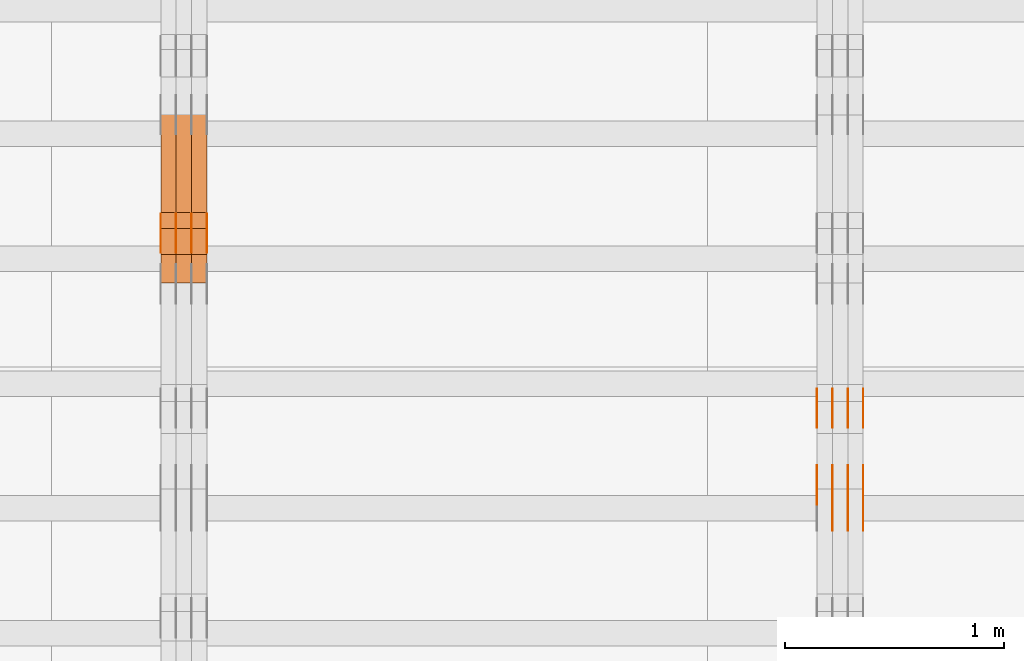
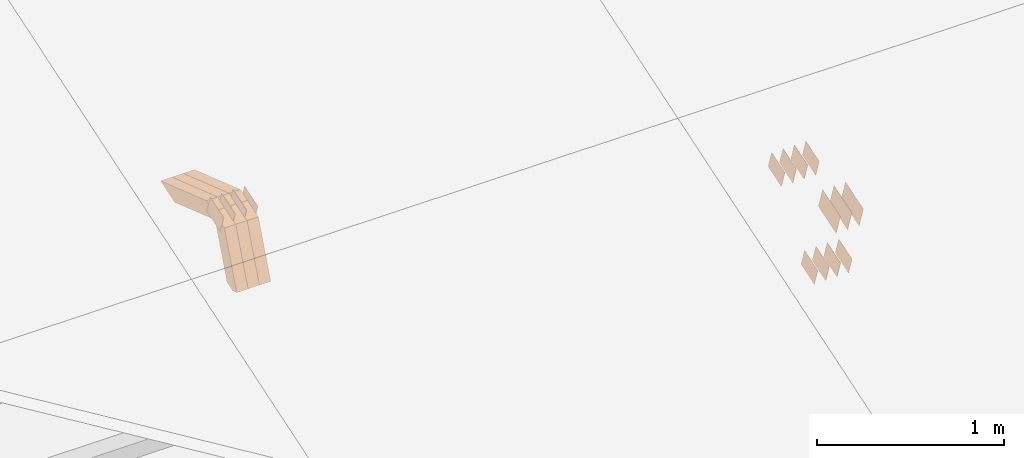
# One storey, part 126 of 385: 28 proxies.
"""IFC2X3 building model written with IfcOpenShell, lengths in millimetres."""

from ifc_helpers import new_model, entity, si_unit, converted_unit, derived_unit, direction, frame, origin, place, context, subcontext, project, spatial, polyline, outline, extrude, source, transform, mapped, material, type_object, type_shapes, element, save


model = new_model("IFC2X3")

# Units and contexts
model_context = context("Model", 3, precision=0.01, world=origin(), true_north=direction((6.12303176911189e-17, 1.0)))
body_context = subcontext(model_context, "Body", "Model", "MODEL_VIEW")
ifc_project = project(units=[si_unit("LENGTHUNIT", "METRE", prefix="MILLI"), si_unit("AREAUNIT", "SQUARE_METRE"), si_unit("VOLUMEUNIT", "CUBIC_METRE"), converted_unit("PLANEANGLEUNIT", "DEGREE", entity("IfcRatioMeasure", 0.0174532925199433), si_unit("PLANEANGLEUNIT", "RADIAN"), dimensions=[0, 0, 0, 0, 0, 0, 0]), si_unit("MASSUNIT", "GRAM", prefix="KILO"), derived_unit("MASSDENSITYUNIT", [(si_unit("MASSUNIT", "GRAM", prefix="KILO"), 1), (si_unit("LENGTHUNIT", "METRE"), -3)]), si_unit("TIMEUNIT", "SECOND"), si_unit("FREQUENCYUNIT", "HERTZ"), si_unit("THERMODYNAMICTEMPERATUREUNIT", "DEGREE_CELSIUS"), derived_unit("THERMALTRANSMITTANCEUNIT", [(si_unit("MASSUNIT", "GRAM", prefix="KILO"), 1), (si_unit("THERMODYNAMICTEMPERATUREUNIT", "KELVIN"), -1), (si_unit("TIMEUNIT", "SECOND"), -3)]), derived_unit("VOLUMETRICFLOWRATEUNIT", [(si_unit("LENGTHUNIT", "METRE"), 3), (si_unit("TIMEUNIT", "SECOND"), -1)]), si_unit("ELECTRICCURRENTUNIT", "AMPERE"), si_unit("ELECTRICVOLTAGEUNIT", "VOLT"), si_unit("POWERUNIT", "WATT"), si_unit("FORCEUNIT", "NEWTON", prefix="KILO"), si_unit("ILLUMINANCEUNIT", "LUX"), si_unit("LUMINOUSFLUXUNIT", "LUMEN"), si_unit("LUMINOUSINTENSITYUNIT", "CANDELA"), derived_unit("USERDEFINED", [(si_unit("MASSUNIT", "GRAM", prefix="KILO"), -1), (si_unit("LENGTHUNIT", "METRE"), -2), (si_unit("TIMEUNIT", "SECOND"), 3), (si_unit("LUMINOUSFLUXUNIT", "LUMEN"), 1)]), derived_unit("LINEARVELOCITYUNIT", [(si_unit("LENGTHUNIT", "METRE"), 1), (si_unit("TIMEUNIT", "SECOND"), -1)]), si_unit("PRESSUREUNIT", "PASCAL"), derived_unit("USERDEFINED", [(si_unit("LENGTHUNIT", "METRE"), -2), (si_unit("MASSUNIT", "GRAM", prefix="KILO"), 1), (si_unit("TIMEUNIT", "SECOND"), -2)])], contexts=[model_context])

# Site, building, storey
site_placement = place(None, origin())
site = spatial("IfcSite", under=ifc_project, at=site_placement, CompositionType="ELEMENT")
building_placement = place(site_placement, origin())
building = spatial("IfcBuilding", under=site, at=building_placement, CompositionType="ELEMENT")
storey_placement = place(building_placement, origin())
storey = spatial("IfcBuildingStorey", under=building, at=storey_placement, Name="Default", CompositionType="ELEMENT", Elevation=0.0)

# Proxies
ifc_material_1 = material(Name="IfcSurfaceStyle #339344")
building_element_proxy_type_1 = type_object("IfcBuildingElementProxyType", PredefinedType="NOTDEFINED", material=ifc_material_1)
shared_shape_1 = source(origin(), body_context, "Body", "SweptSolid", [
    extrude(outline(polyline([(-74.9998707133927, -60.0000596852269), (74.9998841352353, -60.0000596852269), (74.999861282944, 60.0000596852269), (-74.9998747047866, 60.0000596852269), (-74.9998707133927, -60.0000596852269)])), frame((74.9998841352353, 60.0000596852269, 0.0), z_axis=(0.0, 0.0, 1.0), x_axis=(-1.0, 0.0, 0.0)), (0.0, 0.0, 1.0), 1.3),
])
type_shapes(building_element_proxy_type_1, [shared_shape_1])
proxy_1_placement = place(building_placement, frame((27386.3, 5067.4882362875, 826.131473120182), z_axis=(-1.0, 0.0, 0.0), x_axis=(0.0, 0.951056516295124, 0.309016994375039)))
element("IfcBuildingElementProxy", 1, at=proxy_1_placement, inside=storey, type_object=building_element_proxy_type_1, material=ifc_material_1, context=body_context, shape_type="MappedRepresentation", body=[
    mapped(shared_shape_1, transform((0.0, 0.0, 0.0), scale=1.0)),
])
ifc_material_2 = material(Name="IfcSurfaceStyle #339287")
building_element_proxy_type_2 = type_object("IfcBuildingElementProxyType", PredefinedType="NOTDEFINED", material=ifc_material_2)
shared_shape_2 = source(origin(), body_context, "Body", "SweptSolid", [
    extrude(outline(polyline([(-74.9998707133927, -60.0000596852269), (74.9998841352353, -60.0000596852269), (74.999861282944, 60.0000596852269), (-74.9998747047866, 60.0000596852269), (-74.9998707133927, -60.0000596852269)])), frame((74.9998841352353, 60.0000596852269, 0.0), z_axis=(0.0, 0.0, 1.0), x_axis=(-1.0, 0.0, 0.0)), (0.0, 0.0, 1.0), 1.3),
])
type_shapes(building_element_proxy_type_2, [shared_shape_2])
proxy_2_placement = place(building_placement, frame((27315.0, 5067.4882362875, 826.131473120182), z_axis=(-1.0, 0.0, 0.0), x_axis=(0.0, 0.951056516295124, 0.309016994375039)))
element("IfcBuildingElementProxy", 2, at=proxy_2_placement, inside=storey, type_object=building_element_proxy_type_2, material=ifc_material_2, context=body_context, shape_type="MappedRepresentation", body=[
    mapped(shared_shape_2, transform((0.0, 0.0, 0.0), scale=1.0)),
])
ifc_material_3 = material(Name="IfcSurfaceStyle #339230")
building_element_proxy_type_3 = type_object("IfcBuildingElementProxyType", PredefinedType="NOTDEFINED", material=ifc_material_3)
shared_shape_3 = source(origin(), body_context, "Body", "SweptSolid", [
    extrude(outline(polyline([(-74.9998707133927, -60.0000596852269), (74.9998841352353, -60.0000596852269), (74.999861282944, 60.0000596852269), (-74.9998747047866, 60.0000596852269), (-74.9998707133927, -60.0000596852269)])), frame((74.9998841352353, 60.0000596852269, 0.0), z_axis=(0.0, 0.0, 1.0), x_axis=(-1.0, 0.0, 0.0)), (0.0, 0.0, 1.0), 1.3),
])
type_shapes(building_element_proxy_type_3, [shared_shape_3])
proxy_3_placement = place(building_placement, frame((27316.3, 5067.4882362875, 826.131473120182), z_axis=(-1.0, 0.0, 0.0), x_axis=(0.0, 0.951056516295124, 0.309016994375039)))
element("IfcBuildingElementProxy", 3, at=proxy_3_placement, inside=storey, type_object=building_element_proxy_type_3, material=ifc_material_3, context=body_context, shape_type="MappedRepresentation", body=[
    mapped(shared_shape_3, transform((0.0, 0.0, 0.0), scale=1.0)),
])
ifc_material_4 = material(Name="IfcSurfaceStyle #339173")
building_element_proxy_type_4 = type_object("IfcBuildingElementProxyType", PredefinedType="NOTDEFINED", material=ifc_material_4)
shared_shape_4 = source(origin(), body_context, "Body", "SweptSolid", [
    extrude(outline(polyline([(-74.9998707133927, -60.0000596852269), (74.9998841352353, -60.0000596852269), (74.999861282944, 60.0000596852269), (-74.9998747047866, 60.0000596852269), (-74.9998707133927, -60.0000596852269)])), frame((74.9998841352353, 60.0000596852269, 0.0), z_axis=(0.0, 0.0, 1.0), x_axis=(-1.0, 0.0, 0.0)), (0.0, 0.0, 1.0), 1.29999999999999),
])
type_shapes(building_element_proxy_type_4, [shared_shape_4])
proxy_4_placement = place(building_placement, frame((27245.0, 5067.4882362875, 826.131473120182), z_axis=(-1.0, 0.0, 0.0), x_axis=(0.0, 0.951056516295124, 0.309016994375039)))
element("IfcBuildingElementProxy", 4, at=proxy_4_placement, inside=storey, type_object=building_element_proxy_type_4, material=ifc_material_4, context=body_context, shape_type="MappedRepresentation", body=[
    mapped(shared_shape_4, transform((0.0, 0.0, 0.0), scale=1.0)),
])
ifc_material_5 = material(Name="IfcSurfaceStyle #339116")
building_element_proxy_type_5 = type_object("IfcBuildingElementProxyType", PredefinedType="NOTDEFINED", material=ifc_material_5)
shared_shape_5 = source(origin(), body_context, "Body", "SweptSolid", [
    extrude(outline(polyline([(-74.9998707133927, -60.0000596852269), (74.9998841352353, -60.0000596852269), (74.999861282944, 60.0000596852269), (-74.9998747047866, 60.0000596852269), (-74.9998707133927, -60.0000596852269)])), frame((74.9998841352353, 60.0000596852269, 0.0), z_axis=(0.0, 0.0, 1.0), x_axis=(-1.0, 0.0, 0.0)), (0.0, 0.0, 1.0), 1.29999999999999),
])
type_shapes(building_element_proxy_type_5, [shared_shape_5])
proxy_5_placement = place(building_placement, frame((27246.3, 5067.4882362875, 826.131473120182), z_axis=(-1.0, 0.0, 0.0), x_axis=(0.0, 0.951056516295124, 0.309016994375039)))
element("IfcBuildingElementProxy", 5, at=proxy_5_placement, inside=storey, type_object=building_element_proxy_type_5, material=ifc_material_5, context=body_context, shape_type="MappedRepresentation", body=[
    mapped(shared_shape_5, transform((0.0, 0.0, 0.0), scale=1.0)),
])
ifc_material_6 = material(Name="IfcSurfaceStyle #339059")
building_element_proxy_type_6 = type_object("IfcBuildingElementProxyType", PredefinedType="NOTDEFINED", material=ifc_material_6)
shared_shape_6 = source(origin(), body_context, "Body", "SweptSolid", [
    extrude(outline(polyline([(-74.9998707133927, -60.0000596852269), (74.9998841352353, -60.0000596852269), (74.999861282944, 60.0000596852269), (-74.9998747047866, 60.0000596852269), (-74.9998707133927, -60.0000596852269)])), frame((74.9998841352353, 60.0000596852269, 0.0), z_axis=(0.0, 0.0, 1.0), x_axis=(-1.0, 0.0, 0.0)), (0.0, 0.0, 1.0), 1.29999999999999),
])
type_shapes(building_element_proxy_type_6, [shared_shape_6])
proxy_6_placement = place(building_placement, frame((27175.0, 5067.4882362875, 826.131473120182), z_axis=(-1.0, 0.0, 0.0), x_axis=(0.0, 0.951056516295124, 0.309016994375039)))
element("IfcBuildingElementProxy", 6, at=proxy_6_placement, inside=storey, type_object=building_element_proxy_type_6, material=ifc_material_6, context=body_context, shape_type="MappedRepresentation", body=[
    mapped(shared_shape_6, transform((0.0, 0.0, 0.0), scale=1.0)),
])
ifc_material_7 = material(Name="IfcSurfaceStyle #333530")
building_element_proxy_type_7 = type_object("IfcBuildingElementProxyType", PredefinedType="NOTDEFINED", material=ifc_material_7)
shared_shape_7 = source(origin(), body_context, "Body", "SweptSolid", [
    extrude(outline(polyline([(-74.9998565677224, -60.0000596852342), (74.9998794200083, -60.0000596852342), (74.9998565677242, 60.0000596852342), (-74.9998794200101, 60.0000596852342), (-74.9998565677224, -60.0000596852342)])), frame((74.9998794200083, 60.0000596852342, 0.0), z_axis=(0.0, 0.0, 1.0), x_axis=(-1.0, 0.0, 0.0)), (0.0, 0.0, 1.0), 1.3),
])
type_shapes(building_element_proxy_type_7, [shared_shape_7])
proxy_7_placement = place(building_placement, frame((27386.3, 5418.69917378751, 1250.81341892098), z_axis=(-1.0, 0.0, 0.0), x_axis=(0.0, 0.951056516295154, 0.309016994374948)))
element("IfcBuildingElementProxy", 7, at=proxy_7_placement, inside=storey, type_object=building_element_proxy_type_7, material=ifc_material_7, context=body_context, shape_type="MappedRepresentation", body=[
    mapped(shared_shape_7, transform((0.0, 0.0, 0.0), scale=1.0)),
])
ifc_material_8 = material(Name="IfcSurfaceStyle #333473")
building_element_proxy_type_8 = type_object("IfcBuildingElementProxyType", PredefinedType="NOTDEFINED", material=ifc_material_8)
shared_shape_8 = source(origin(), body_context, "Body", "SweptSolid", [
    extrude(outline(polyline([(-74.9998565677224, -60.0000596852342), (74.9998794200083, -60.0000596852342), (74.9998565677242, 60.0000596852342), (-74.9998794200101, 60.0000596852342), (-74.9998565677224, -60.0000596852342)])), frame((74.9998794200083, 60.0000596852342, 0.0), z_axis=(0.0, 0.0, 1.0), x_axis=(-1.0, 0.0, 0.0)), (0.0, 0.0, 1.0), 1.3),
])
type_shapes(building_element_proxy_type_8, [shared_shape_8])
proxy_8_placement = place(building_placement, frame((27315.0, 5418.69917378751, 1250.81341892098), z_axis=(-1.0, 0.0, 0.0), x_axis=(0.0, 0.951056516295154, 0.309016994374948)))
element("IfcBuildingElementProxy", 8, at=proxy_8_placement, inside=storey, type_object=building_element_proxy_type_8, material=ifc_material_8, context=body_context, shape_type="MappedRepresentation", body=[
    mapped(shared_shape_8, transform((0.0, 0.0, 0.0), scale=1.0)),
])
ifc_material_9 = material(Name="IfcSurfaceStyle #333416")
building_element_proxy_type_9 = type_object("IfcBuildingElementProxyType", PredefinedType="NOTDEFINED", material=ifc_material_9)
shared_shape_9 = source(origin(), body_context, "Body", "SweptSolid", [
    extrude(outline(polyline([(-74.9998565677224, -60.0000596852342), (74.9998794200083, -60.0000596852342), (74.9998565677242, 60.0000596852342), (-74.9998794200101, 60.0000596852342), (-74.9998565677224, -60.0000596852342)])), frame((74.9998794200083, 60.0000596852342, 0.0), z_axis=(0.0, 0.0, 1.0), x_axis=(-1.0, 0.0, 0.0)), (0.0, 0.0, 1.0), 1.3),
])
type_shapes(building_element_proxy_type_9, [shared_shape_9])
proxy_9_placement = place(building_placement, frame((27316.3, 5418.69917378751, 1250.81341892098), z_axis=(-1.0, 0.0, 0.0), x_axis=(0.0, 0.951056516295154, 0.309016994374948)))
element("IfcBuildingElementProxy", 9, at=proxy_9_placement, inside=storey, type_object=building_element_proxy_type_9, material=ifc_material_9, context=body_context, shape_type="MappedRepresentation", body=[
    mapped(shared_shape_9, transform((0.0, 0.0, 0.0), scale=1.0)),
])
ifc_material_10 = material(Name="IfcSurfaceStyle #333359")
building_element_proxy_type_10 = type_object("IfcBuildingElementProxyType", PredefinedType="NOTDEFINED", material=ifc_material_10)
shared_shape_10 = source(origin(), body_context, "Body", "SweptSolid", [
    extrude(outline(polyline([(-74.9998565677224, -60.0000596852342), (74.9998794200083, -60.0000596852342), (74.9998565677242, 60.0000596852342), (-74.9998794200101, 60.0000596852342), (-74.9998565677224, -60.0000596852342)])), frame((74.9998794200083, 60.0000596852342, 0.0), z_axis=(0.0, 0.0, 1.0), x_axis=(-1.0, 0.0, 0.0)), (0.0, 0.0, 1.0), 1.29999999999999),
])
type_shapes(building_element_proxy_type_10, [shared_shape_10])
proxy_10_placement = place(building_placement, frame((27245.0, 5418.69917378751, 1250.81341892098), z_axis=(-1.0, 0.0, 0.0), x_axis=(0.0, 0.951056516295154, 0.309016994374948)))
element("IfcBuildingElementProxy", 10, at=proxy_10_placement, inside=storey, type_object=building_element_proxy_type_10, material=ifc_material_10, context=body_context, shape_type="MappedRepresentation", body=[
    mapped(shared_shape_10, transform((0.0, 0.0, 0.0), scale=1.0)),
])
ifc_material_11 = material(Name="IfcSurfaceStyle #333302")
building_element_proxy_type_11 = type_object("IfcBuildingElementProxyType", PredefinedType="NOTDEFINED", material=ifc_material_11)
shared_shape_11 = source(origin(), body_context, "Body", "SweptSolid", [
    extrude(outline(polyline([(-74.9998565677224, -60.0000596852342), (74.9998794200083, -60.0000596852342), (74.9998565677242, 60.0000596852342), (-74.9998794200101, 60.0000596852342), (-74.9998565677224, -60.0000596852342)])), frame((74.9998794200083, 60.0000596852342, 0.0), z_axis=(0.0, 0.0, 1.0), x_axis=(-1.0, 0.0, 0.0)), (0.0, 0.0, 1.0), 1.29999999999999),
])
type_shapes(building_element_proxy_type_11, [shared_shape_11])
proxy_11_placement = place(building_placement, frame((27246.3, 5418.69917378751, 1250.81341892098), z_axis=(-1.0, 0.0, 0.0), x_axis=(0.0, 0.951056516295154, 0.309016994374948)))
element("IfcBuildingElementProxy", 11, at=proxy_11_placement, inside=storey, type_object=building_element_proxy_type_11, material=ifc_material_11, context=body_context, shape_type="MappedRepresentation", body=[
    mapped(shared_shape_11, transform((0.0, 0.0, 0.0), scale=1.0)),
])
ifc_material_12 = material(Name="IfcSurfaceStyle #333245")
building_element_proxy_type_12 = type_object("IfcBuildingElementProxyType", PredefinedType="NOTDEFINED", material=ifc_material_12)
shared_shape_12 = source(origin(), body_context, "Body", "SweptSolid", [
    extrude(outline(polyline([(-74.9998565677224, -60.0000596852342), (74.9998794200083, -60.0000596852342), (74.9998565677242, 60.0000596852342), (-74.9998794200101, 60.0000596852342), (-74.9998565677224, -60.0000596852342)])), frame((74.9998794200083, 60.0000596852342, 0.0), z_axis=(0.0, 0.0, 1.0), x_axis=(-1.0, 0.0, 0.0)), (0.0, 0.0, 1.0), 1.29999999999999),
])
type_shapes(building_element_proxy_type_12, [shared_shape_12])
proxy_12_placement = place(building_placement, frame((27175.0, 5418.69917378751, 1250.81341892098), z_axis=(-1.0, 0.0, 0.0), x_axis=(0.0, 0.951056516295154, 0.309016994374948)))
element("IfcBuildingElementProxy", 12, at=proxy_12_placement, inside=storey, type_object=building_element_proxy_type_12, material=ifc_material_12, context=body_context, shape_type="MappedRepresentation", body=[
    mapped(shared_shape_12, transform((0.0, 0.0, 0.0), scale=1.0)),
])
ifc_material_13 = material(Name="IfcSurfaceStyle #330110")
building_element_proxy_type_13 = type_object("IfcBuildingElementProxyType", PredefinedType="NOTDEFINED", material=ifc_material_13)
shared_shape_13 = source(origin(), body_context, "Body", "SweptSolid", [
    extrude(outline(polyline([(-99.9996257846169, -71.999973710258), (100.000009625089, -71.999973710258), (99.9996257846187, 71.999973710258), (-100.000009625091, 71.999973710258), (-99.9996257846169, -71.999973710258)])), frame((100.000083496635, 72.0000008245779, 0.0), z_axis=(0.0, 0.0, 1.0), x_axis=(-1.0, 0.0, 0.0)), (0.0, 0.0, 1.0), 1.3),
])
type_shapes(building_element_proxy_type_13, [shared_shape_13])
proxy_13_placement = place(building_placement, frame((27386.3, 4947.73195917317, 1225.53937157357), z_axis=(-1.0, 0.0, 0.0), x_axis=(0.0, 0.951056516295154, 0.309016994374948)))
element("IfcBuildingElementProxy", 13, at=proxy_13_placement, inside=storey, type_object=building_element_proxy_type_13, material=ifc_material_13, context=body_context, shape_type="MappedRepresentation", body=[
    mapped(shared_shape_13, transform((0.0, 0.0, 0.0), scale=1.0)),
])
ifc_material_14 = material(Name="IfcSurfaceStyle #330053")
building_element_proxy_type_14 = type_object("IfcBuildingElementProxyType", PredefinedType="NOTDEFINED", material=ifc_material_14)
shared_shape_14 = source(origin(), body_context, "Body", "SweptSolid", [
    extrude(outline(polyline([(-99.9996257846169, -71.999973710258), (100.000009625089, -71.999973710258), (99.9996257846187, 71.999973710258), (-100.000009625091, 71.999973710258), (-99.9996257846169, -71.999973710258)])), frame((100.000083496635, 72.0000008245779, 0.0), z_axis=(0.0, 0.0, 1.0), x_axis=(-1.0, 0.0, 0.0)), (0.0, 0.0, 1.0), 1.3),
])
type_shapes(building_element_proxy_type_14, [shared_shape_14])
proxy_14_placement = place(building_placement, frame((27315.0, 4947.73195917317, 1225.53937157357), z_axis=(-1.0, 0.0, 0.0), x_axis=(0.0, 0.951056516295154, 0.309016994374948)))
element("IfcBuildingElementProxy", 14, at=proxy_14_placement, inside=storey, type_object=building_element_proxy_type_14, material=ifc_material_14, context=body_context, shape_type="MappedRepresentation", body=[
    mapped(shared_shape_14, transform((0.0, 0.0, 0.0), scale=1.0)),
])
ifc_material_15 = material(Name="IfcSurfaceStyle #329996")
building_element_proxy_type_15 = type_object("IfcBuildingElementProxyType", PredefinedType="NOTDEFINED", material=ifc_material_15)
shared_shape_15 = source(origin(), body_context, "Body", "SweptSolid", [
    extrude(outline(polyline([(-99.9996257846169, -71.999973710258), (100.000009625089, -71.999973710258), (99.9996257846187, 71.999973710258), (-100.000009625091, 71.999973710258), (-99.9996257846169, -71.999973710258)])), frame((100.000083496635, 72.0000008245779, 0.0), z_axis=(0.0, 0.0, 1.0), x_axis=(-1.0, 0.0, 0.0)), (0.0, 0.0, 1.0), 1.3),
])
type_shapes(building_element_proxy_type_15, [shared_shape_15])
proxy_15_placement = place(building_placement, frame((27316.3, 4947.73195917317, 1225.53937157357), z_axis=(-1.0, 0.0, 0.0), x_axis=(0.0, 0.951056516295154, 0.309016994374948)))
element("IfcBuildingElementProxy", 15, at=proxy_15_placement, inside=storey, type_object=building_element_proxy_type_15, material=ifc_material_15, context=body_context, shape_type="MappedRepresentation", body=[
    mapped(shared_shape_15, transform((0.0, 0.0, 0.0), scale=1.0)),
])
ifc_material_16 = material(Name="IfcSurfaceStyle #329939")
building_element_proxy_type_16 = type_object("IfcBuildingElementProxyType", PredefinedType="NOTDEFINED", material=ifc_material_16)
shared_shape_16 = source(origin(), body_context, "Body", "SweptSolid", [
    extrude(outline(polyline([(-99.9996257846169, -71.999973710258), (100.000009625089, -71.999973710258), (99.9996257846187, 71.999973710258), (-100.000009625091, 71.999973710258), (-99.9996257846169, -71.999973710258)])), frame((100.000083496635, 72.0000008245779, 0.0), z_axis=(0.0, 0.0, 1.0), x_axis=(-1.0, 0.0, 0.0)), (0.0, 0.0, 1.0), 1.29999999999998),
])
type_shapes(building_element_proxy_type_16, [shared_shape_16])
proxy_16_placement = place(building_placement, frame((27245.0, 4947.73195917317, 1225.53937157357), z_axis=(-1.0, 0.0, 0.0), x_axis=(0.0, 0.951056516295154, 0.309016994374948)))
element("IfcBuildingElementProxy", 16, at=proxy_16_placement, inside=storey, type_object=building_element_proxy_type_16, material=ifc_material_16, context=body_context, shape_type="MappedRepresentation", body=[
    mapped(shared_shape_16, transform((0.0, 0.0, 0.0), scale=1.0)),
])
ifc_material_17 = material(Name="IfcSurfaceStyle #300124")
building_element_proxy_type_17 = type_object("IfcBuildingElementProxyType", PredefinedType="NOTDEFINED", material=ifc_material_17)
shared_shape_17 = source(origin(), body_context, "Body", "SweptSolid", [
    extrude(outline(polyline([(-74.9998754286253, -60.0000016373506), (74.999860559109, -60.0000016373506), (74.9998754286235, 60.0000016373506), (-74.9998605591072, 60.0000016373506), (-74.9998754286253, -60.0000016373506)])), frame((75.0001009411744, 60.0000279841752, 0.0), z_axis=(0.0, 0.0, 1.0), x_axis=(-1.0, 0.0, 0.0)), (0.0, 0.0, 1.0), 1.3),
])
type_shapes(building_element_proxy_type_17, [shared_shape_17])
proxy_17_placement = place(building_placement, frame((24386.3, 6218.29662915452, 1523.23574463408), z_axis=(-1.0, 0.0, 0.0), x_axis=(0.0, 0.951056516295154, 0.309016994374948)))
element("IfcBuildingElementProxy", 17, at=proxy_17_placement, inside=storey, type_object=building_element_proxy_type_17, material=ifc_material_17, context=body_context, shape_type="MappedRepresentation", body=[
    mapped(shared_shape_17, transform((0.0, 0.0, 0.0), scale=1.0)),
])
ifc_material_18 = material(Name="IfcSurfaceStyle #300067")
building_element_proxy_type_18 = type_object("IfcBuildingElementProxyType", PredefinedType="NOTDEFINED", material=ifc_material_18)
shared_shape_18 = source(origin(), body_context, "Body", "SweptSolid", [
    extrude(outline(polyline([(-74.9998754286253, -60.0000016373506), (74.999860559109, -60.0000016373506), (74.9998754286235, 60.0000016373506), (-74.9998605591072, 60.0000016373506), (-74.9998754286253, -60.0000016373506)])), frame((75.0001009411744, 60.0000279841752, 0.0), z_axis=(0.0, 0.0, 1.0), x_axis=(-1.0, 0.0, 0.0)), (0.0, 0.0, 1.0), 1.3),
])
type_shapes(building_element_proxy_type_18, [shared_shape_18])
proxy_18_placement = place(building_placement, frame((24315.0, 6218.29662915452, 1523.23574463408), z_axis=(-1.0, 0.0, 0.0), x_axis=(0.0, 0.951056516295154, 0.309016994374948)))
element("IfcBuildingElementProxy", 18, at=proxy_18_placement, inside=storey, type_object=building_element_proxy_type_18, material=ifc_material_18, context=body_context, shape_type="MappedRepresentation", body=[
    mapped(shared_shape_18, transform((0.0, 0.0, 0.0), scale=1.0)),
])
ifc_material_19 = material(Name="IfcSurfaceStyle #300010")
building_element_proxy_type_19 = type_object("IfcBuildingElementProxyType", PredefinedType="NOTDEFINED", material=ifc_material_19)
shared_shape_19 = source(origin(), body_context, "Body", "SweptSolid", [
    extrude(outline(polyline([(-74.9998754286253, -60.0000016373506), (74.999860559109, -60.0000016373506), (74.9998754286235, 60.0000016373506), (-74.9998605591072, 60.0000016373506), (-74.9998754286253, -60.0000016373506)])), frame((75.0001009411744, 60.0000279841752, 0.0), z_axis=(0.0, 0.0, 1.0), x_axis=(-1.0, 0.0, 0.0)), (0.0, 0.0, 1.0), 1.3),
])
type_shapes(building_element_proxy_type_19, [shared_shape_19])
proxy_19_placement = place(building_placement, frame((24316.3, 6218.29662915452, 1523.23574463408), z_axis=(-1.0, 0.0, 0.0), x_axis=(0.0, 0.951056516295154, 0.309016994374948)))
element("IfcBuildingElementProxy", 19, at=proxy_19_placement, inside=storey, type_object=building_element_proxy_type_19, material=ifc_material_19, context=body_context, shape_type="MappedRepresentation", body=[
    mapped(shared_shape_19, transform((0.0, 0.0, 0.0), scale=1.0)),
])
ifc_material_20 = material(Name="IfcSurfaceStyle #299953")
building_element_proxy_type_20 = type_object("IfcBuildingElementProxyType", PredefinedType="NOTDEFINED", material=ifc_material_20)
shared_shape_20 = source(origin(), body_context, "Body", "SweptSolid", [
    extrude(outline(polyline([(-74.9998754286253, -60.0000016373506), (74.999860559109, -60.0000016373506), (74.9998754286235, 60.0000016373506), (-74.9998605591072, 60.0000016373506), (-74.9998754286253, -60.0000016373506)])), frame((75.0001009411744, 60.0000279841752, 0.0), z_axis=(0.0, 0.0, 1.0), x_axis=(-1.0, 0.0, 0.0)), (0.0, 0.0, 1.0), 1.29999999999999),
])
type_shapes(building_element_proxy_type_20, [shared_shape_20])
proxy_20_placement = place(building_placement, frame((24245.0, 6218.29662915452, 1523.23574463408), z_axis=(-1.0, 0.0, 0.0), x_axis=(0.0, 0.951056516295154, 0.309016994374948)))
element("IfcBuildingElementProxy", 20, at=proxy_20_placement, inside=storey, type_object=building_element_proxy_type_20, material=ifc_material_20, context=body_context, shape_type="MappedRepresentation", body=[
    mapped(shared_shape_20, transform((0.0, 0.0, 0.0), scale=1.0)),
])
ifc_material_21 = material(Name="IfcSurfaceStyle #299896")
building_element_proxy_type_21 = type_object("IfcBuildingElementProxyType", PredefinedType="NOTDEFINED", material=ifc_material_21)
shared_shape_21 = source(origin(), body_context, "Body", "SweptSolid", [
    extrude(outline(polyline([(-74.9998754286253, -60.0000016373506), (74.999860559109, -60.0000016373506), (74.9998754286235, 60.0000016373506), (-74.9998605591072, 60.0000016373506), (-74.9998754286253, -60.0000016373506)])), frame((75.0001009411744, 60.0000279841752, 0.0), z_axis=(0.0, 0.0, 1.0), x_axis=(-1.0, 0.0, 0.0)), (0.0, 0.0, 1.0), 1.29999999999999),
])
type_shapes(building_element_proxy_type_21, [shared_shape_21])
proxy_21_placement = place(building_placement, frame((24246.3, 6218.29662915452, 1523.23574463408), z_axis=(-1.0, 0.0, 0.0), x_axis=(0.0, 0.951056516295154, 0.309016994374948)))
element("IfcBuildingElementProxy", 21, at=proxy_21_placement, inside=storey, type_object=building_element_proxy_type_21, material=ifc_material_21, context=body_context, shape_type="MappedRepresentation", body=[
    mapped(shared_shape_21, transform((0.0, 0.0, 0.0), scale=1.0)),
])
ifc_material_22 = material(Name="IfcSurfaceStyle #299839")
building_element_proxy_type_22 = type_object("IfcBuildingElementProxyType", PredefinedType="NOTDEFINED", material=ifc_material_22)
shared_shape_22 = source(origin(), body_context, "Body", "SweptSolid", [
    extrude(outline(polyline([(-74.9998754286253, -60.0000016373506), (74.999860559109, -60.0000016373506), (74.9998754286235, 60.0000016373506), (-74.9998605591072, 60.0000016373506), (-74.9998754286253, -60.0000016373506)])), frame((75.0001009411744, 60.0000279841752, 0.0), z_axis=(0.0, 0.0, 1.0), x_axis=(-1.0, 0.0, 0.0)), (0.0, 0.0, 1.0), 1.29999999999999),
])
type_shapes(building_element_proxy_type_22, [shared_shape_22])
proxy_22_placement = place(building_placement, frame((24175.0, 6218.29662915452, 1523.23574463408), z_axis=(-1.0, 0.0, 0.0), x_axis=(0.0, 0.951056516295154, 0.309016994374948)))
element("IfcBuildingElementProxy", 22, at=proxy_22_placement, inside=storey, type_object=building_element_proxy_type_22, material=ifc_material_22, context=body_context, shape_type="MappedRepresentation", body=[
    mapped(shared_shape_22, transform((0.0, 0.0, 0.0), scale=1.0)),
])
ifc_material_23 = material(Name="IfcSurfaceStyle #287128")
building_element_proxy_type_23 = type_object("IfcBuildingElementProxyType", Name="T1-W19 287126", PredefinedType="NOTDEFINED", material=ifc_material_23)
shared_shape_23 = source(origin(), body_context, "Body", "SweptSolid", [
    extrude(outline(polyline([(-234.986199656822, -47.5000587840676), (221.224626701627, -47.5000587840676), (219.29748584664, -9.04449542012076e-05), (156.014457007826, 47.5001040065446), (-361.550369899272, 47.5001040065447), (-234.986199656822, -47.5000587840676)])), frame((221.224626701627, 47.5001108598228, 0.0), z_axis=(0.0, 0.0, 1.0), x_axis=(-1.0, 0.0, 0.0)), (0.0, 0.0, 1.0), 70.0),
])
type_shapes(building_element_proxy_type_23, [shared_shape_23])
proxy_23_placement = place(building_placement, frame((24385.0, 6342.4042570111, 1541.63383639481), z_axis=(-1.0, 0.0, 0.0), x_axis=(0.0, 0.9461301511345, -0.323786561046329)))
element("IfcBuildingElementProxy", 23, at=proxy_23_placement, inside=storey, type_object=building_element_proxy_type_23, material=ifc_material_23, Name="T1-W19", context=body_context, shape_type="MappedRepresentation", body=[
    mapped(shared_shape_23, transform((0.0, 0.0, 0.0), scale=1.0)),
])
ifc_material_24 = material(Name="IfcSurfaceStyle #287062")
building_element_proxy_type_24 = type_object("IfcBuildingElementProxyType", Name="T1-W19 287060", PredefinedType="NOTDEFINED", material=ifc_material_24)
shared_shape_24 = source(origin(), body_context, "Body", "SweptSolid", [
    extrude(outline(polyline([(-234.986199656822, -47.5000587840676), (221.224626701627, -47.5000587840676), (219.29748584664, -9.04449542012076e-05), (156.014457007826, 47.5001040065446), (-361.550369899272, 47.5001040065447), (-234.986199656822, -47.5000587840676)])), frame((221.224626701627, 47.5001108598228, 0.0), z_axis=(0.0, 0.0, 1.0), x_axis=(-1.0, 0.0, 0.0)), (0.0, 0.0, 1.0), 70.0),
])
type_shapes(building_element_proxy_type_24, [shared_shape_24])
proxy_24_placement = place(building_placement, frame((24315.0, 6342.4042570111, 1541.63383639481), z_axis=(-1.0, 0.0, 0.0), x_axis=(0.0, 0.9461301511345, -0.323786561046329)))
element("IfcBuildingElementProxy", 24, at=proxy_24_placement, inside=storey, type_object=building_element_proxy_type_24, material=ifc_material_24, Name="T1-W19", context=body_context, shape_type="MappedRepresentation", body=[
    mapped(shared_shape_24, transform((0.0, 0.0, 0.0), scale=1.0)),
])
ifc_material_25 = material(Name="IfcSurfaceStyle #286996")
building_element_proxy_type_25 = type_object("IfcBuildingElementProxyType", Name="T1-W19 286994", PredefinedType="NOTDEFINED", material=ifc_material_25)
shared_shape_25 = source(origin(), body_context, "Body", "SweptSolid", [
    extrude(outline(polyline([(-234.986199656822, -47.5000587840676), (221.224626701627, -47.5000587840676), (219.29748584664, -9.04449542012076e-05), (156.014457007826, 47.5001040065446), (-361.550369899272, 47.5001040065447), (-234.986199656822, -47.5000587840676)])), frame((221.224626701627, 47.5001108598228, 0.0), z_axis=(0.0, 0.0, 1.0), x_axis=(-1.0, 0.0, 0.0)), (0.0, 0.0, 1.0), 70.0),
])
type_shapes(building_element_proxy_type_25, [shared_shape_25])
proxy_25_placement = place(building_placement, frame((24245.0, 6342.4042570111, 1541.63383639481), z_axis=(-1.0, 0.0, 0.0), x_axis=(0.0, 0.9461301511345, -0.323786561046329)))
element("IfcBuildingElementProxy", 25, at=proxy_25_placement, inside=storey, type_object=building_element_proxy_type_25, material=ifc_material_25, Name="T1-W19", context=body_context, shape_type="MappedRepresentation", body=[
    mapped(shared_shape_25, transform((0.0, 0.0, 0.0), scale=1.0)),
])
ifc_material_26 = material(Name="IfcSurfaceStyle #286732")
building_element_proxy_type_26 = type_object("IfcBuildingElementProxyType", Name="T1-W46 286730", PredefinedType="NOTDEFINED", material=ifc_material_26)
shared_shape_26 = source(origin(), body_context, "Body", "SweptSolid", [
    extrude(outline(polyline([(-272.224583017384, -47.5002947748381), (128.798007350946, -47.5002947748382), (167.560249082673, 0.000339032424879266), (170.567132940603, 47.500741369691), (-194.700806356838, 47.4995091475604), (-272.224583017384, -47.5002947748381)])), frame((170.567293182179, 47.5001659655231, 0.0), z_axis=(0.0, 0.0, 1.0), x_axis=(-1.0, 3.37347464168628e-06, 0.0)), (0.0, 0.0, 1.0), 70.0),
])
type_shapes(building_element_proxy_type_26, [shared_shape_26])
proxy_26_placement = place(building_placement, frame((24385.0, 6080.046875, 1117.66674804688), z_axis=(-1.0, 0.0, 0.0), x_axis=(0.0, 0.361885618189232, 0.93222250527854)))
element("IfcBuildingElementProxy", 26, at=proxy_26_placement, inside=storey, type_object=building_element_proxy_type_26, material=ifc_material_26, Name="T1-W46", context=body_context, shape_type="MappedRepresentation", body=[
    mapped(shared_shape_26, transform((0.0, 0.0, 0.0), scale=1.0)),
])
ifc_material_27 = material(Name="IfcSurfaceStyle #286666")
building_element_proxy_type_27 = type_object("IfcBuildingElementProxyType", Name="T1-W46 286664", PredefinedType="NOTDEFINED", material=ifc_material_27)
shared_shape_27 = source(origin(), body_context, "Body", "SweptSolid", [
    extrude(outline(polyline([(-272.224583017384, -47.5002947748381), (128.798007350946, -47.5002947748382), (167.560249082673, 0.000339032424879266), (170.567132940603, 47.500741369691), (-194.700806356838, 47.4995091475604), (-272.224583017384, -47.5002947748381)])), frame((170.567293182179, 47.5001659655231, 0.0), z_axis=(0.0, 0.0, 1.0), x_axis=(-1.0, 3.37347464168628e-06, 0.0)), (0.0, 0.0, 1.0), 70.0),
])
type_shapes(building_element_proxy_type_27, [shared_shape_27])
proxy_27_placement = place(building_placement, frame((24315.0, 6080.046875, 1117.66674804688), z_axis=(-1.0, 0.0, 0.0), x_axis=(0.0, 0.361885618189232, 0.93222250527854)))
element("IfcBuildingElementProxy", 27, at=proxy_27_placement, inside=storey, type_object=building_element_proxy_type_27, material=ifc_material_27, Name="T1-W46", context=body_context, shape_type="MappedRepresentation", body=[
    mapped(shared_shape_27, transform((0.0, 0.0, 0.0), scale=1.0)),
])
ifc_material_28 = material(Name="IfcSurfaceStyle #286600")
building_element_proxy_type_28 = type_object("IfcBuildingElementProxyType", Name="T1-W46 286598", PredefinedType="NOTDEFINED", material=ifc_material_28)
shared_shape_28 = source(origin(), body_context, "Body", "SweptSolid", [
    extrude(outline(polyline([(-272.224583017384, -47.5002947748381), (128.798007350946, -47.5002947748382), (167.560249082673, 0.000339032424879266), (170.567132940603, 47.500741369691), (-194.700806356838, 47.4995091475604), (-272.224583017384, -47.5002947748381)])), frame((170.567293182179, 47.5001659655231, 0.0), z_axis=(0.0, 0.0, 1.0), x_axis=(-1.0, 3.37347464168628e-06, 0.0)), (0.0, 0.0, 1.0), 70.0),
])
type_shapes(building_element_proxy_type_28, [shared_shape_28])
proxy_28_placement = place(building_placement, frame((24245.0, 6080.046875, 1117.66674804688), z_axis=(-1.0, 0.0, 0.0), x_axis=(0.0, 0.361885618189232, 0.93222250527854)))
element("IfcBuildingElementProxy", 28, at=proxy_28_placement, inside=storey, type_object=building_element_proxy_type_28, material=ifc_material_28, Name="T1-W46", context=body_context, shape_type="MappedRepresentation", body=[
    mapped(shared_shape_28, transform((0.0, 0.0, 0.0), scale=1.0)),
])

save(model, "model.ifc")
